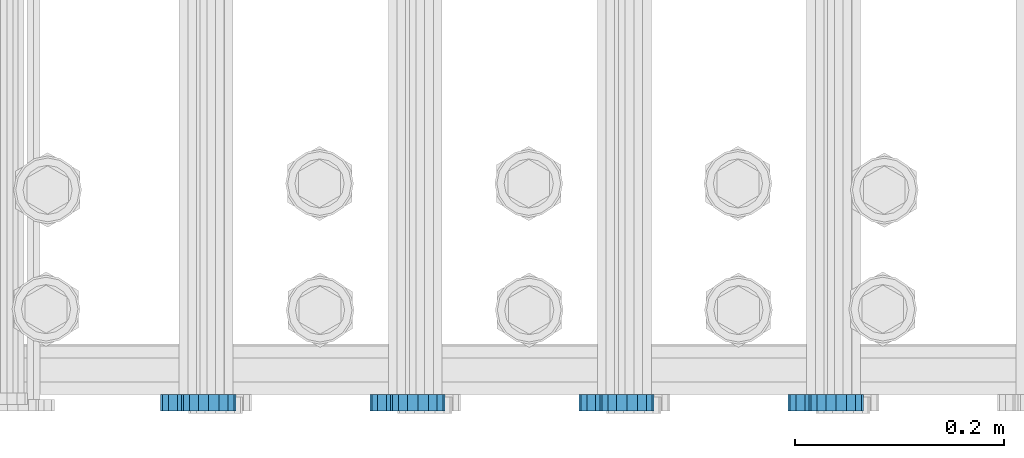
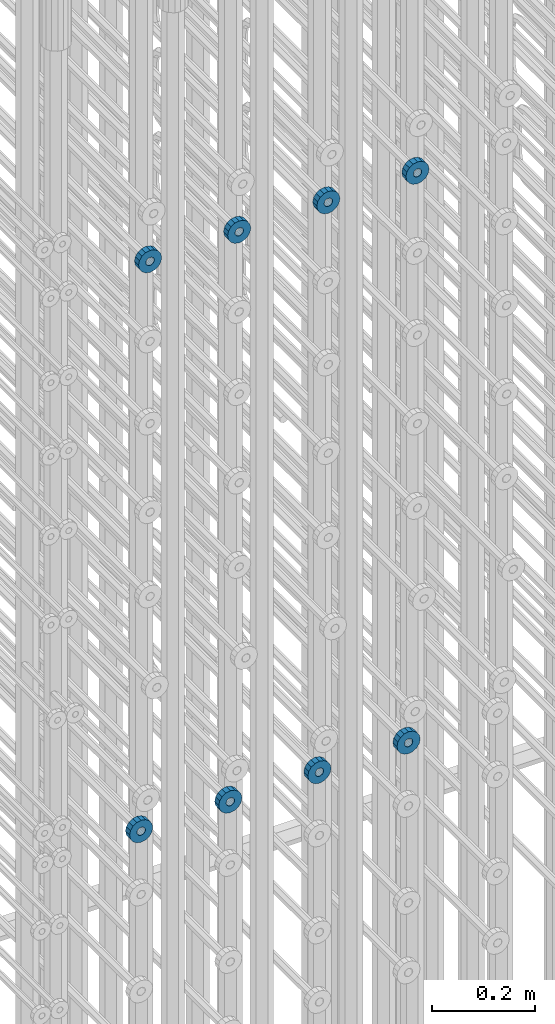
# One storey, part 130 of 177: 8 beams.
"""IFC2X3 building model written with IfcOpenShell, lengths in millimetres."""

from ifc_helpers import new_model, si_unit, frame, origin_with_axes, place, context, subcontext, project, spatial, faceted_brep, material, type_object, element, save


model = new_model("IFC2X3")

# Units and contexts
model_context_1 = context("Model", 3, precision=1e-05, world=origin_with_axes())
model_context_2 = context("Model", 3, precision=1e-05, world=origin_with_axes())
body_context = subcontext(model_context_2, "Body", "Model", "MODEL_VIEW")
ifc_project = project(units=[si_unit("LENGTHUNIT", "METRE", prefix="MILLI"), si_unit("AREAUNIT", "SQUARE_METRE"), si_unit("VOLUMEUNIT", "CUBIC_METRE"), si_unit("MASSUNIT", "GRAM", prefix="KILO"), si_unit("TIMEUNIT", "SECOND"), si_unit("PLANEANGLEUNIT", "RADIAN"), si_unit("SOLIDANGLEUNIT", "STERADIAN"), si_unit("THERMODYNAMICTEMPERATUREUNIT", "DEGREE_CELSIUS"), si_unit("LUMINOUSINTENSITYUNIT", "LUMEN")], contexts=[model_context_1])

# Site, building, storey
site_placement = place(None, origin_with_axes())
site = spatial("IfcSite", under=ifc_project, at=site_placement, CompositionType="ELEMENT")
building_placement = place(site_placement, origin_with_axes())
building = spatial("IfcBuilding", under=site, at=building_placement, Name="Undefined", CompositionType="ELEMENT")
storey_placement = place(building_placement, origin_with_axes())
storey = spatial("IfcBuildingStorey", under=building, at=storey_placement, Name="Undefined", CompositionType="ELEMENT", Elevation=0.0)

# Beams
ifc_material = material(Name="STEEL/Steel_Undefined")
beam_type = type_object("IfcBeamType", PredefinedType="NOTDEFINED")
beam_1_placement = place(storey_placement, frame((2032309.49847349, 6205075.98588033, 20799.9868114421), z_axis=(0.0, 0.0, -1.0), x_axis=(0.0, -1.0, 0.0)))
element("IfcBeam", 1, at=beam_1_placement, inside=storey, type_object=beam_type, material=ifc_material, context=body_context, shape_type="Brep", body=[
    faceted_brep([(0.0, -9.5, 0.0), (0.0, -8.77685555908829, 3.63549260746731), (16.0, -8.77685555908829, 3.63549260746731), (16.0, -9.5, 0.0), (0.0, -6.71751442085952, 6.71751442127061), (16.0, -6.71751442085952, 6.71751442127061), (0.0, -3.63549260701984, 8.77685555885546), (16.0, -3.63549260701984, 8.77685555885546), (-2.02452244836415e-12, 0.0, 9.5), (16.0, 0.0, 9.5), (0.0, 3.63549260701984, 8.77685555885546), (16.0, 3.63549260701984, 8.77685555885546), (0.0, 6.71751442085952, 6.71751442127061), (16.0, 6.71751442085952, 6.71751442127061), (0.0, 8.77685555908829, 3.63549260746731), (16.0, 8.77685555908829, 3.63549260746731), (0.0, 9.5, 0.0), (16.0, 9.5, 0.0), (0.0, 8.77685555908829, -3.63549260746731), (16.0, 8.77685555908829, -3.63549260746731), (0.0, 6.71751442085952, -6.71751442127061), (16.0, 6.71751442085952, -6.71751442127061), (0.0, 3.63549260701984, -8.77685555885546), (16.0, 3.63549260701984, -8.77685555885546), (2.02452244836415e-12, -3.69149155687865e-15, -9.5), (16.0, 0.0, -9.5), (0.0, -3.63549260701984, -8.77685555885546), (16.0, -3.63549260701984, -8.77685555885546), (0.0, -6.71751442085952, -6.71751442127061), (16.0, -6.71751442085952, -6.71751442127061), (0.0, -8.77685555908829, -3.63549260746731), (16.0, -8.77685555908829, -3.63549260746731), (0.0, -26.0, 0.0), (0.0, -24.0208678450435, -9.94976924149159), (16.0, -24.0208678450435, -9.94976924149159), (16.0, -26.0, 0.0), (0.0, -18.3847763109952, -18.3847763108497), (16.0, -18.3847763109952, -18.3847763108497), (0.0, -9.94976924173534, -24.0208678452946), (16.0, -9.94976924173534, -24.0208678452946), (0.0, 0.0, -26.0), (16.0, 0.0, -26.0), (0.0, 9.94976924173534, -24.0208678452946), (16.0, 9.94976924173534, -24.0208678452946), (0.0, 18.3847763109952, -18.3847763108497), (16.0, 18.3847763109952, -18.3847763108497), (0.0, 24.0208678450435, -9.94976924149159), (16.0, 24.0208678450435, -9.94976924149159), (0.0, 26.0, 0.0), (16.0, 26.0, 0.0), (0.0, 24.0208678450435, 9.94976924149159), (16.0, 24.0208678450435, 9.94976924149159), (0.0, 18.3847763109952, 18.3847763108497), (16.0, 18.3847763109952, 18.3847763108497), (0.0, 9.94976924173534, 24.0208678452946), (16.0, 9.94976924173534, 24.0208678452946), (0.0, 0.0, 26.0), (16.0, 0.0, 26.0), (0.0, -9.94976924173534, 24.0208678452946), (16.0, -9.94976924173534, 24.0208678452946), (0.0, -18.3847763109952, 18.3847763108497), (16.0, -18.3847763109952, 18.3847763108497), (0.0, -24.0208678450435, 9.94976924149159), (16.0, -24.0208678450435, 9.94976924149159)], [[[0, 1, 2, 3]], [[1, 4, 5, 2]], [[4, 6, 7, 5]], [[6, 8, 9, 7]], [[8, 10, 11, 9]], [[10, 12, 13, 11]], [[12, 14, 15, 13]], [[14, 16, 17, 15]], [[16, 18, 19, 17]], [[18, 20, 21, 19]], [[20, 22, 23, 21]], [[22, 24, 25, 23]], [[24, 26, 27, 25]], [[26, 28, 29, 27]], [[28, 30, 31, 29]], [[30, 0, 3, 31]], [[32, 33, 34, 35]], [[33, 36, 37, 34]], [[36, 38, 39, 37]], [[38, 40, 41, 39]], [[40, 42, 43, 41]], [[42, 44, 45, 43]], [[44, 46, 47, 45]], [[46, 48, 49, 47]], [[48, 50, 51, 49]], [[50, 52, 53, 51]], [[52, 54, 55, 53]], [[54, 56, 57, 55]], [[56, 58, 59, 57]], [[58, 60, 61, 59]], [[60, 62, 63, 61]], [[62, 32, 35, 63]], [[37, 39, 41, 43, 45, 47, 49, 51, 53, 55, 57, 59, 61, 63, 35, 34], [5, 7, 9, 11, 13, 15, 17, 19, 21, 23, 25, 27, 29, 31, 3, 2]], [[62, 60, 58, 56, 54, 52, 50, 48, 46, 44, 42, 40, 38, 36, 33, 32], [30, 28, 26, 24, 22, 20, 18, 16, 14, 12, 10, 8, 6, 4, 1, 0]]]),
])
beam_2_placement = place(storey_placement, frame((2032509.49847349, 6205075.98588033, 20799.9868114421), z_axis=(0.0, 0.0, -1.0), x_axis=(0.0, -1.0, 0.0)))
element("IfcBeam", 2, at=beam_2_placement, inside=storey, type_object=beam_type, material=ifc_material, context=body_context, shape_type="Brep", body=[
    faceted_brep([(0.0, -9.5, 0.0), (0.0, -8.77685555908829, 3.63549260746731), (16.0, -8.77685555908829, 3.63549260746731), (16.0, -9.5, 0.0), (0.0, -6.71751442085952, 6.71751442127061), (16.0, -6.71751442085952, 6.71751442127061), (0.0, -3.63549260701984, 8.77685555885546), (16.0, -3.63549260701984, 8.77685555885546), (-2.02452244836415e-12, 0.0, 9.5), (16.0, 0.0, 9.5), (0.0, 3.63549260701984, 8.77685555885546), (16.0, 3.63549260701984, 8.77685555885546), (0.0, 6.71751442085952, 6.71751442127061), (16.0, 6.71751442085952, 6.71751442127061), (0.0, 8.77685555908829, 3.63549260746731), (16.0, 8.77685555908829, 3.63549260746731), (0.0, 9.5, 0.0), (16.0, 9.5, 0.0), (0.0, 8.77685555908829, -3.63549260746731), (16.0, 8.77685555908829, -3.63549260746731), (0.0, 6.71751442085952, -6.71751442127061), (16.0, 6.71751442085952, -6.71751442127061), (0.0, 3.63549260701984, -8.77685555885546), (16.0, 3.63549260701984, -8.77685555885546), (2.02452244836415e-12, -3.69149155687865e-15, -9.5), (16.0, 0.0, -9.5), (0.0, -3.63549260701984, -8.77685555885546), (16.0, -3.63549260701984, -8.77685555885546), (0.0, -6.71751442085952, -6.71751442127061), (16.0, -6.71751442085952, -6.71751442127061), (0.0, -8.77685555908829, -3.63549260746731), (16.0, -8.77685555908829, -3.63549260746731), (0.0, -26.0, 0.0), (0.0, -24.0208678450435, -9.94976924149159), (16.0, -24.0208678450435, -9.94976924149159), (16.0, -26.0, 0.0), (0.0, -18.3847763109952, -18.3847763108497), (16.0, -18.3847763109952, -18.3847763108497), (0.0, -9.94976924173534, -24.0208678452946), (16.0, -9.94976924173534, -24.0208678452946), (0.0, 0.0, -26.0), (16.0, 0.0, -26.0), (0.0, 9.94976924173534, -24.0208678452946), (16.0, 9.94976924173534, -24.0208678452946), (0.0, 18.3847763109952, -18.3847763108497), (16.0, 18.3847763109952, -18.3847763108497), (0.0, 24.0208678450435, -9.94976924149159), (16.0, 24.0208678450435, -9.94976924149159), (0.0, 26.0, 0.0), (16.0, 26.0, 0.0), (0.0, 24.0208678450435, 9.94976924149159), (16.0, 24.0208678450435, 9.94976924149159), (0.0, 18.3847763109952, 18.3847763108497), (16.0, 18.3847763109952, 18.3847763108497), (0.0, 9.94976924173534, 24.0208678452946), (16.0, 9.94976924173534, 24.0208678452946), (0.0, 0.0, 26.0), (16.0, 0.0, 26.0), (0.0, -9.94976924173534, 24.0208678452946), (16.0, -9.94976924173534, 24.0208678452946), (0.0, -18.3847763109952, 18.3847763108497), (16.0, -18.3847763109952, 18.3847763108497), (0.0, -24.0208678450435, 9.94976924149159), (16.0, -24.0208678450435, 9.94976924149159)], [[[0, 1, 2, 3]], [[1, 4, 5, 2]], [[4, 6, 7, 5]], [[6, 8, 9, 7]], [[8, 10, 11, 9]], [[10, 12, 13, 11]], [[12, 14, 15, 13]], [[14, 16, 17, 15]], [[16, 18, 19, 17]], [[18, 20, 21, 19]], [[20, 22, 23, 21]], [[22, 24, 25, 23]], [[24, 26, 27, 25]], [[26, 28, 29, 27]], [[28, 30, 31, 29]], [[30, 0, 3, 31]], [[32, 33, 34, 35]], [[33, 36, 37, 34]], [[36, 38, 39, 37]], [[38, 40, 41, 39]], [[40, 42, 43, 41]], [[42, 44, 45, 43]], [[44, 46, 47, 45]], [[46, 48, 49, 47]], [[48, 50, 51, 49]], [[50, 52, 53, 51]], [[52, 54, 55, 53]], [[54, 56, 57, 55]], [[56, 58, 59, 57]], [[58, 60, 61, 59]], [[60, 62, 63, 61]], [[62, 32, 35, 63]], [[37, 39, 41, 43, 45, 47, 49, 51, 53, 55, 57, 59, 61, 63, 35, 34], [5, 7, 9, 11, 13, 15, 17, 19, 21, 23, 25, 27, 29, 31, 3, 2]], [[62, 60, 58, 56, 54, 52, 50, 48, 46, 44, 42, 40, 38, 36, 33, 32], [30, 28, 26, 24, 22, 20, 18, 16, 14, 12, 10, 8, 6, 4, 1, 0]]]),
])
beam_3_placement = place(storey_placement, frame((2032109.49847349, 6205075.98588033, 20799.9868114421), z_axis=(0.0, 0.0, -1.0), x_axis=(0.0, -1.0, 0.0)))
element("IfcBeam", 3, at=beam_3_placement, inside=storey, type_object=beam_type, material=ifc_material, context=body_context, shape_type="Brep", body=[
    faceted_brep([(0.0, -9.5, 0.0), (0.0, -8.77685555908829, 3.63549260746731), (16.0, -8.77685555908829, 3.63549260746731), (16.0, -9.5, 0.0), (0.0, -6.71751442085952, 6.71751442127061), (16.0, -6.71751442085952, 6.71751442127061), (0.0, -3.63549260701984, 8.77685555885546), (16.0, -3.63549260701984, 8.77685555885546), (-2.02452244836415e-12, 0.0, 9.5), (16.0, 0.0, 9.5), (0.0, 3.63549260701984, 8.77685555885546), (16.0, 3.63549260701984, 8.77685555885546), (0.0, 6.71751442085952, 6.71751442127061), (16.0, 6.71751442085952, 6.71751442127061), (0.0, 8.77685555908829, 3.63549260746731), (16.0, 8.77685555908829, 3.63549260746731), (0.0, 9.5, 0.0), (16.0, 9.5, 0.0), (0.0, 8.77685555908829, -3.63549260746731), (16.0, 8.77685555908829, -3.63549260746731), (0.0, 6.71751442085952, -6.71751442127061), (16.0, 6.71751442085952, -6.71751442127061), (0.0, 3.63549260701984, -8.77685555885546), (16.0, 3.63549260701984, -8.77685555885546), (2.02452244836415e-12, -3.69149155687865e-15, -9.5), (16.0, 0.0, -9.5), (0.0, -3.63549260701984, -8.77685555885546), (16.0, -3.63549260701984, -8.77685555885546), (0.0, -6.71751442085952, -6.71751442127061), (16.0, -6.71751442085952, -6.71751442127061), (0.0, -8.77685555908829, -3.63549260746731), (16.0, -8.77685555908829, -3.63549260746731), (0.0, -26.0, 0.0), (0.0, -24.0208678450435, -9.94976924149159), (16.0, -24.0208678450435, -9.94976924149159), (16.0, -26.0, 0.0), (0.0, -18.3847763109952, -18.3847763108497), (16.0, -18.3847763109952, -18.3847763108497), (0.0, -9.94976924173534, -24.0208678452946), (16.0, -9.94976924173534, -24.0208678452946), (0.0, 0.0, -26.0), (16.0, 0.0, -26.0), (0.0, 9.94976924173534, -24.0208678452946), (16.0, 9.94976924173534, -24.0208678452946), (0.0, 18.3847763109952, -18.3847763108497), (16.0, 18.3847763109952, -18.3847763108497), (0.0, 24.0208678450435, -9.94976924149159), (16.0, 24.0208678450435, -9.94976924149159), (0.0, 26.0, 0.0), (16.0, 26.0, 0.0), (0.0, 24.0208678450435, 9.94976924149159), (16.0, 24.0208678450435, 9.94976924149159), (0.0, 18.3847763109952, 18.3847763108497), (16.0, 18.3847763109952, 18.3847763108497), (0.0, 9.94976924173534, 24.0208678452946), (16.0, 9.94976924173534, 24.0208678452946), (0.0, 0.0, 26.0), (16.0, 0.0, 26.0), (0.0, -9.94976924173534, 24.0208678452946), (16.0, -9.94976924173534, 24.0208678452946), (0.0, -18.3847763109952, 18.3847763108497), (16.0, -18.3847763109952, 18.3847763108497), (0.0, -24.0208678450435, 9.94976924149159), (16.0, -24.0208678450435, 9.94976924149159)], [[[0, 1, 2, 3]], [[1, 4, 5, 2]], [[4, 6, 7, 5]], [[6, 8, 9, 7]], [[8, 10, 11, 9]], [[10, 12, 13, 11]], [[12, 14, 15, 13]], [[14, 16, 17, 15]], [[16, 18, 19, 17]], [[18, 20, 21, 19]], [[20, 22, 23, 21]], [[22, 24, 25, 23]], [[24, 26, 27, 25]], [[26, 28, 29, 27]], [[28, 30, 31, 29]], [[30, 0, 3, 31]], [[32, 33, 34, 35]], [[33, 36, 37, 34]], [[36, 38, 39, 37]], [[38, 40, 41, 39]], [[40, 42, 43, 41]], [[42, 44, 45, 43]], [[44, 46, 47, 45]], [[46, 48, 49, 47]], [[48, 50, 51, 49]], [[50, 52, 53, 51]], [[52, 54, 55, 53]], [[54, 56, 57, 55]], [[56, 58, 59, 57]], [[58, 60, 61, 59]], [[60, 62, 63, 61]], [[62, 32, 35, 63]], [[37, 39, 41, 43, 45, 47, 49, 51, 53, 55, 57, 59, 61, 63, 35, 34], [5, 7, 9, 11, 13, 15, 17, 19, 21, 23, 25, 27, 29, 31, 3, 2]], [[62, 60, 58, 56, 54, 52, 50, 48, 46, 44, 42, 40, 38, 36, 33, 32], [30, 28, 26, 24, 22, 20, 18, 16, 14, 12, 10, 8, 6, 4, 1, 0]]]),
])
beam_4_placement = place(storey_placement, frame((2032709.49847349, 6205075.98588033, 20799.9868114424), z_axis=(0.0, 0.0, -1.0), x_axis=(0.0, -1.0, 0.0)))
element("IfcBeam", 4, at=beam_4_placement, inside=storey, type_object=beam_type, material=ifc_material, context=body_context, shape_type="Brep", body=[
    faceted_brep([(0.0, -9.5, 0.0), (0.0, -8.77685555908829, 3.63549260746731), (16.0, -8.77685555908829, 3.63549260746731), (16.0, -9.5, 0.0), (0.0, -6.71751442085952, 6.71751442127061), (16.0, -6.71751442085952, 6.71751442127061), (0.0, -3.63549260701984, 8.77685555885546), (16.0, -3.63549260701984, 8.77685555885546), (-2.02452244836415e-12, 0.0, 9.5), (16.0, 0.0, 9.5), (0.0, 3.63549260701984, 8.77685555885546), (16.0, 3.63549260701984, 8.77685555885546), (0.0, 6.71751442085952, 6.71751442127061), (16.0, 6.71751442085952, 6.71751442127061), (0.0, 8.77685555908829, 3.63549260746731), (16.0, 8.77685555908829, 3.63549260746731), (0.0, 9.5, 0.0), (16.0, 9.5, 0.0), (0.0, 8.77685555908829, -3.63549260746731), (16.0, 8.77685555908829, -3.63549260746731), (0.0, 6.71751442085952, -6.71751442127061), (16.0, 6.71751442085952, -6.71751442127061), (0.0, 3.63549260701984, -8.77685555885546), (16.0, 3.63549260701984, -8.77685555885546), (2.02452244836415e-12, -3.69149155687865e-15, -9.5), (16.0, 0.0, -9.5), (0.0, -3.63549260701984, -8.77685555885546), (16.0, -3.63549260701984, -8.77685555885546), (0.0, -6.71751442085952, -6.71751442127061), (16.0, -6.71751442085952, -6.71751442127061), (0.0, -8.77685555908829, -3.63549260746731), (16.0, -8.77685555908829, -3.63549260746731), (0.0, -26.0, 0.0), (0.0, -24.0208678450435, -9.94976924149159), (16.0, -24.0208678450435, -9.94976924149159), (16.0, -26.0, 0.0), (0.0, -18.3847763109952, -18.3847763108497), (16.0, -18.3847763109952, -18.3847763108497), (0.0, -9.94976924173534, -24.0208678452946), (16.0, -9.94976924173534, -24.0208678452946), (0.0, 0.0, -26.0), (16.0, 0.0, -26.0), (0.0, 9.94976924173534, -24.0208678452946), (16.0, 9.94976924173534, -24.0208678452946), (0.0, 18.3847763109952, -18.3847763108497), (16.0, 18.3847763109952, -18.3847763108497), (0.0, 24.0208678450435, -9.94976924149159), (16.0, 24.0208678450435, -9.94976924149159), (0.0, 26.0, 0.0), (16.0, 26.0, 0.0), (0.0, 24.0208678450435, 9.94976924149159), (16.0, 24.0208678450435, 9.94976924149159), (0.0, 18.3847763109952, 18.3847763108497), (16.0, 18.3847763109952, 18.3847763108497), (0.0, 9.94976924173534, 24.0208678452946), (16.0, 9.94976924173534, 24.0208678452946), (0.0, 0.0, 26.0), (16.0, 0.0, 26.0), (0.0, -9.94976924173534, 24.0208678452946), (16.0, -9.94976924173534, 24.0208678452946), (0.0, -18.3847763109952, 18.3847763108497), (16.0, -18.3847763109952, 18.3847763108497), (0.0, -24.0208678450435, 9.94976924149159), (16.0, -24.0208678450435, 9.94976924149159)], [[[0, 1, 2, 3]], [[1, 4, 5, 2]], [[4, 6, 7, 5]], [[6, 8, 9, 7]], [[8, 10, 11, 9]], [[10, 12, 13, 11]], [[12, 14, 15, 13]], [[14, 16, 17, 15]], [[16, 18, 19, 17]], [[18, 20, 21, 19]], [[20, 22, 23, 21]], [[22, 24, 25, 23]], [[24, 26, 27, 25]], [[26, 28, 29, 27]], [[28, 30, 31, 29]], [[30, 0, 3, 31]], [[32, 33, 34, 35]], [[33, 36, 37, 34]], [[36, 38, 39, 37]], [[38, 40, 41, 39]], [[40, 42, 43, 41]], [[42, 44, 45, 43]], [[44, 46, 47, 45]], [[46, 48, 49, 47]], [[48, 50, 51, 49]], [[50, 52, 53, 51]], [[52, 54, 55, 53]], [[54, 56, 57, 55]], [[56, 58, 59, 57]], [[58, 60, 61, 59]], [[60, 62, 63, 61]], [[62, 32, 35, 63]], [[37, 39, 41, 43, 45, 47, 49, 51, 53, 55, 57, 59, 61, 63, 35, 34], [5, 7, 9, 11, 13, 15, 17, 19, 21, 23, 25, 27, 29, 31, 3, 2]], [[62, 60, 58, 56, 54, 52, 50, 48, 46, 44, 42, 40, 38, 36, 33, 32], [30, 28, 26, 24, 22, 20, 18, 16, 14, 12, 10, 8, 6, 4, 1, 0]]]),
])
beam_5_placement = place(storey_placement, frame((2032729.49847313, 6205075.98588636, 22144.986812672), z_axis=(0.0, 0.0, -1.0), x_axis=(0.0, -1.0, 0.0)))
element("IfcBeam", 5, at=beam_5_placement, inside=storey, type_object=beam_type, material=ifc_material, context=body_context, shape_type="Brep", body=[
    faceted_brep([(0.0, -9.5, 0.0), (0.0, -8.77685555908829, 3.63549260746731), (16.0, -8.77685555908829, 3.63549260746731), (16.0, -9.5, 0.0), (0.0, -6.71751442085952, 6.71751442127061), (16.0, -6.71751442085952, 6.71751442127061), (0.0, -3.63549260701984, 8.77685555885546), (16.0, -3.63549260701984, 8.77685555885546), (-2.02452244836415e-12, 0.0, 9.5), (16.0, 0.0, 9.5), (0.0, 3.63549260701984, 8.77685555885546), (16.0, 3.63549260701984, 8.77685555885546), (0.0, 6.71751442085952, 6.71751442127061), (16.0, 6.71751442085952, 6.71751442127061), (0.0, 8.77685555908829, 3.63549260746731), (16.0, 8.77685555908829, 3.63549260746731), (0.0, 9.5, 0.0), (16.0, 9.5, 0.0), (0.0, 8.77685555908829, -3.63549260746731), (16.0, 8.77685555908829, -3.63549260746731), (0.0, 6.71751442085952, -6.71751442127061), (16.0, 6.71751442085952, -6.71751442127061), (0.0, 3.63549260701984, -8.77685555885546), (16.0, 3.63549260701984, -8.77685555885546), (2.02452244836415e-12, -3.69149155687865e-15, -9.5), (16.0, 0.0, -9.5), (0.0, -3.63549260701984, -8.77685555885546), (16.0, -3.63549260701984, -8.77685555885546), (0.0, -6.71751442085952, -6.71751442127061), (16.0, -6.71751442085952, -6.71751442127061), (0.0, -8.77685555908829, -3.63549260746731), (16.0, -8.77685555908829, -3.63549260746731), (0.0, -26.0, 0.0), (0.0, -24.0208678450435, -9.94976924149159), (16.0, -24.0208678450435, -9.94976924149159), (16.0, -26.0, 0.0), (0.0, -18.3847763109952, -18.3847763108497), (16.0, -18.3847763109952, -18.3847763108497), (0.0, -9.94976924173534, -24.0208678452946), (16.0, -9.94976924173534, -24.0208678452946), (0.0, 0.0, -26.0), (16.0, 0.0, -26.0), (0.0, 9.94976924173534, -24.0208678452946), (16.0, 9.94976924173534, -24.0208678452946), (0.0, 18.3847763109952, -18.3847763108497), (16.0, 18.3847763109952, -18.3847763108497), (0.0, 24.0208678450435, -9.94976924149159), (16.0, 24.0208678450435, -9.94976924149159), (0.0, 26.0, 0.0), (16.0, 26.0, 0.0), (0.0, 24.0208678450435, 9.94976924149159), (16.0, 24.0208678450435, 9.94976924149159), (0.0, 18.3847763109952, 18.3847763108497), (16.0, 18.3847763109952, 18.3847763108497), (0.0, 9.94976924173534, 24.0208678452946), (16.0, 9.94976924173534, 24.0208678452946), (0.0, 0.0, 26.0), (16.0, 0.0, 26.0), (0.0, -9.94976924173534, 24.0208678452946), (16.0, -9.94976924173534, 24.0208678452946), (0.0, -18.3847763109952, 18.3847763108497), (16.0, -18.3847763109952, 18.3847763108497), (0.0, -24.0208678450435, 9.94976924149159), (16.0, -24.0208678450435, 9.94976924149159)], [[[0, 1, 2, 3]], [[1, 4, 5, 2]], [[4, 6, 7, 5]], [[6, 8, 9, 7]], [[8, 10, 11, 9]], [[10, 12, 13, 11]], [[12, 14, 15, 13]], [[14, 16, 17, 15]], [[16, 18, 19, 17]], [[18, 20, 21, 19]], [[20, 22, 23, 21]], [[22, 24, 25, 23]], [[24, 26, 27, 25]], [[26, 28, 29, 27]], [[28, 30, 31, 29]], [[30, 0, 3, 31]], [[32, 33, 34, 35]], [[33, 36, 37, 34]], [[36, 38, 39, 37]], [[38, 40, 41, 39]], [[40, 42, 43, 41]], [[42, 44, 45, 43]], [[44, 46, 47, 45]], [[46, 48, 49, 47]], [[48, 50, 51, 49]], [[50, 52, 53, 51]], [[52, 54, 55, 53]], [[54, 56, 57, 55]], [[56, 58, 59, 57]], [[58, 60, 61, 59]], [[60, 62, 63, 61]], [[62, 32, 35, 63]], [[37, 39, 41, 43, 45, 47, 49, 51, 53, 55, 57, 59, 61, 63, 35, 34], [5, 7, 9, 11, 13, 15, 17, 19, 21, 23, 25, 27, 29, 31, 3, 2]], [[62, 60, 58, 56, 54, 52, 50, 48, 46, 44, 42, 40, 38, 36, 33, 32], [30, 28, 26, 24, 22, 20, 18, 16, 14, 12, 10, 8, 6, 4, 1, 0]]]),
])
beam_6_placement = place(storey_placement, frame((2032529.49847313, 6205075.98588636, 22144.986812672), z_axis=(0.0, 0.0, -1.0), x_axis=(0.0, -1.0, 0.0)))
element("IfcBeam", 6, at=beam_6_placement, inside=storey, type_object=beam_type, material=ifc_material, context=body_context, shape_type="Brep", body=[
    faceted_brep([(0.0, -9.5, 0.0), (0.0, -8.77685555908829, 3.63549260746731), (16.0, -8.77685555908829, 3.63549260746731), (16.0, -9.5, 0.0), (0.0, -6.71751442085952, 6.71751442127061), (16.0, -6.71751442085952, 6.71751442127061), (0.0, -3.63549260701984, 8.77685555885546), (16.0, -3.63549260701984, 8.77685555885546), (-2.02452244836415e-12, 0.0, 9.5), (16.0, 0.0, 9.5), (0.0, 3.63549260701984, 8.77685555885546), (16.0, 3.63549260701984, 8.77685555885546), (0.0, 6.71751442085952, 6.71751442127061), (16.0, 6.71751442085952, 6.71751442127061), (0.0, 8.77685555908829, 3.63549260746731), (16.0, 8.77685555908829, 3.63549260746731), (0.0, 9.5, 0.0), (16.0, 9.5, 0.0), (0.0, 8.77685555908829, -3.63549260746731), (16.0, 8.77685555908829, -3.63549260746731), (0.0, 6.71751442085952, -6.71751442127061), (16.0, 6.71751442085952, -6.71751442127061), (0.0, 3.63549260701984, -8.77685555885546), (16.0, 3.63549260701984, -8.77685555885546), (2.02452244836415e-12, -3.69149155687865e-15, -9.5), (16.0, 0.0, -9.5), (0.0, -3.63549260701984, -8.77685555885546), (16.0, -3.63549260701984, -8.77685555885546), (0.0, -6.71751442085952, -6.71751442127061), (16.0, -6.71751442085952, -6.71751442127061), (0.0, -8.77685555908829, -3.63549260746731), (16.0, -8.77685555908829, -3.63549260746731), (0.0, -26.0, 0.0), (0.0, -24.0208678450435, -9.94976924149159), (16.0, -24.0208678450435, -9.94976924149159), (16.0, -26.0, 0.0), (0.0, -18.3847763109952, -18.3847763108497), (16.0, -18.3847763109952, -18.3847763108497), (0.0, -9.94976924173534, -24.0208678452946), (16.0, -9.94976924173534, -24.0208678452946), (0.0, 0.0, -26.0), (16.0, 0.0, -26.0), (0.0, 9.94976924173534, -24.0208678452946), (16.0, 9.94976924173534, -24.0208678452946), (0.0, 18.3847763109952, -18.3847763108497), (16.0, 18.3847763109952, -18.3847763108497), (0.0, 24.0208678450435, -9.94976924149159), (16.0, 24.0208678450435, -9.94976924149159), (0.0, 26.0, 0.0), (16.0, 26.0, 0.0), (0.0, 24.0208678450435, 9.94976924149159), (16.0, 24.0208678450435, 9.94976924149159), (0.0, 18.3847763109952, 18.3847763108497), (16.0, 18.3847763109952, 18.3847763108497), (0.0, 9.94976924173534, 24.0208678452946), (16.0, 9.94976924173534, 24.0208678452946), (0.0, 0.0, 26.0), (16.0, 0.0, 26.0), (0.0, -9.94976924173534, 24.0208678452946), (16.0, -9.94976924173534, 24.0208678452946), (0.0, -18.3847763109952, 18.3847763108497), (16.0, -18.3847763109952, 18.3847763108497), (0.0, -24.0208678450435, 9.94976924149159), (16.0, -24.0208678450435, 9.94976924149159)], [[[0, 1, 2, 3]], [[1, 4, 5, 2]], [[4, 6, 7, 5]], [[6, 8, 9, 7]], [[8, 10, 11, 9]], [[10, 12, 13, 11]], [[12, 14, 15, 13]], [[14, 16, 17, 15]], [[16, 18, 19, 17]], [[18, 20, 21, 19]], [[20, 22, 23, 21]], [[22, 24, 25, 23]], [[24, 26, 27, 25]], [[26, 28, 29, 27]], [[28, 30, 31, 29]], [[30, 0, 3, 31]], [[32, 33, 34, 35]], [[33, 36, 37, 34]], [[36, 38, 39, 37]], [[38, 40, 41, 39]], [[40, 42, 43, 41]], [[42, 44, 45, 43]], [[44, 46, 47, 45]], [[46, 48, 49, 47]], [[48, 50, 51, 49]], [[50, 52, 53, 51]], [[52, 54, 55, 53]], [[54, 56, 57, 55]], [[56, 58, 59, 57]], [[58, 60, 61, 59]], [[60, 62, 63, 61]], [[62, 32, 35, 63]], [[37, 39, 41, 43, 45, 47, 49, 51, 53, 55, 57, 59, 61, 63, 35, 34], [5, 7, 9, 11, 13, 15, 17, 19, 21, 23, 25, 27, 29, 31, 3, 2]], [[62, 60, 58, 56, 54, 52, 50, 48, 46, 44, 42, 40, 38, 36, 33, 32], [30, 28, 26, 24, 22, 20, 18, 16, 14, 12, 10, 8, 6, 4, 1, 0]]]),
])
beam_7_placement = place(storey_placement, frame((2032329.49847313, 6205075.98588636, 22144.986812672), z_axis=(0.0, 0.0, -1.0), x_axis=(0.0, -1.0, 0.0)))
element("IfcBeam", 7, at=beam_7_placement, inside=storey, type_object=beam_type, material=ifc_material, context=body_context, shape_type="Brep", body=[
    faceted_brep([(0.0, -9.5, 0.0), (0.0, -8.77685555908829, 3.63549260746731), (16.0, -8.77685555908829, 3.63549260746731), (16.0, -9.5, 0.0), (0.0, -6.71751442085952, 6.71751442127061), (16.0, -6.71751442085952, 6.71751442127061), (0.0, -3.63549260701984, 8.77685555885546), (16.0, -3.63549260701984, 8.77685555885546), (-2.02452244836415e-12, 0.0, 9.5), (16.0, 0.0, 9.5), (0.0, 3.63549260701984, 8.77685555885546), (16.0, 3.63549260701984, 8.77685555885546), (0.0, 6.71751442085952, 6.71751442127061), (16.0, 6.71751442085952, 6.71751442127061), (0.0, 8.77685555908829, 3.63549260746731), (16.0, 8.77685555908829, 3.63549260746731), (0.0, 9.5, 0.0), (16.0, 9.5, 0.0), (0.0, 8.77685555908829, -3.63549260746731), (16.0, 8.77685555908829, -3.63549260746731), (0.0, 6.71751442085952, -6.71751442127061), (16.0, 6.71751442085952, -6.71751442127061), (0.0, 3.63549260701984, -8.77685555885546), (16.0, 3.63549260701984, -8.77685555885546), (2.02452244836415e-12, -3.69149155687865e-15, -9.5), (16.0, 0.0, -9.5), (0.0, -3.63549260701984, -8.77685555885546), (16.0, -3.63549260701984, -8.77685555885546), (0.0, -6.71751442085952, -6.71751442127061), (16.0, -6.71751442085952, -6.71751442127061), (0.0, -8.77685555908829, -3.63549260746731), (16.0, -8.77685555908829, -3.63549260746731), (0.0, -26.0, 0.0), (0.0, -24.0208678450435, -9.94976924149159), (16.0, -24.0208678450435, -9.94976924149159), (16.0, -26.0, 0.0), (0.0, -18.3847763109952, -18.3847763108497), (16.0, -18.3847763109952, -18.3847763108497), (0.0, -9.94976924173534, -24.0208678452946), (16.0, -9.94976924173534, -24.0208678452946), (0.0, 0.0, -26.0), (16.0, 0.0, -26.0), (0.0, 9.94976924173534, -24.0208678452946), (16.0, 9.94976924173534, -24.0208678452946), (0.0, 18.3847763109952, -18.3847763108497), (16.0, 18.3847763109952, -18.3847763108497), (0.0, 24.0208678450435, -9.94976924149159), (16.0, 24.0208678450435, -9.94976924149159), (0.0, 26.0, 0.0), (16.0, 26.0, 0.0), (0.0, 24.0208678450435, 9.94976924149159), (16.0, 24.0208678450435, 9.94976924149159), (0.0, 18.3847763109952, 18.3847763108497), (16.0, 18.3847763109952, 18.3847763108497), (0.0, 9.94976924173534, 24.0208678452946), (16.0, 9.94976924173534, 24.0208678452946), (0.0, 0.0, 26.0), (16.0, 0.0, 26.0), (0.0, -9.94976924173534, 24.0208678452946), (16.0, -9.94976924173534, 24.0208678452946), (0.0, -18.3847763109952, 18.3847763108497), (16.0, -18.3847763109952, 18.3847763108497), (0.0, -24.0208678450435, 9.94976924149159), (16.0, -24.0208678450435, 9.94976924149159)], [[[0, 1, 2, 3]], [[1, 4, 5, 2]], [[4, 6, 7, 5]], [[6, 8, 9, 7]], [[8, 10, 11, 9]], [[10, 12, 13, 11]], [[12, 14, 15, 13]], [[14, 16, 17, 15]], [[16, 18, 19, 17]], [[18, 20, 21, 19]], [[20, 22, 23, 21]], [[22, 24, 25, 23]], [[24, 26, 27, 25]], [[26, 28, 29, 27]], [[28, 30, 31, 29]], [[30, 0, 3, 31]], [[32, 33, 34, 35]], [[33, 36, 37, 34]], [[36, 38, 39, 37]], [[38, 40, 41, 39]], [[40, 42, 43, 41]], [[42, 44, 45, 43]], [[44, 46, 47, 45]], [[46, 48, 49, 47]], [[48, 50, 51, 49]], [[50, 52, 53, 51]], [[52, 54, 55, 53]], [[54, 56, 57, 55]], [[56, 58, 59, 57]], [[58, 60, 61, 59]], [[60, 62, 63, 61]], [[62, 32, 35, 63]], [[37, 39, 41, 43, 45, 47, 49, 51, 53, 55, 57, 59, 61, 63, 35, 34], [5, 7, 9, 11, 13, 15, 17, 19, 21, 23, 25, 27, 29, 31, 3, 2]], [[62, 60, 58, 56, 54, 52, 50, 48, 46, 44, 42, 40, 38, 36, 33, 32], [30, 28, 26, 24, 22, 20, 18, 16, 14, 12, 10, 8, 6, 4, 1, 0]]]),
])
beam_8_placement = place(storey_placement, frame((2032129.49847313, 6205075.98588636, 22144.986812672), z_axis=(0.0, 0.0, -1.0), x_axis=(0.0, -1.0, 0.0)))
element("IfcBeam", 8, at=beam_8_placement, inside=storey, type_object=beam_type, material=ifc_material, context=body_context, shape_type="Brep", body=[
    faceted_brep([(0.0, -9.5, 0.0), (0.0, -8.77685555908829, 3.63549260746731), (16.0, -8.77685555908829, 3.63549260746731), (16.0, -9.5, 0.0), (0.0, -6.71751442085952, 6.71751442127061), (16.0, -6.71751442085952, 6.71751442127061), (0.0, -3.63549260701984, 8.77685555885546), (16.0, -3.63549260701984, 8.77685555885546), (-2.02452244836415e-12, 0.0, 9.5), (16.0, 0.0, 9.5), (0.0, 3.63549260701984, 8.77685555885546), (16.0, 3.63549260701984, 8.77685555885546), (0.0, 6.71751442085952, 6.71751442127061), (16.0, 6.71751442085952, 6.71751442127061), (0.0, 8.77685555908829, 3.63549260746731), (16.0, 8.77685555908829, 3.63549260746731), (0.0, 9.5, 0.0), (16.0, 9.5, 0.0), (0.0, 8.77685555908829, -3.63549260746731), (16.0, 8.77685555908829, -3.63549260746731), (0.0, 6.71751442085952, -6.71751442127061), (16.0, 6.71751442085952, -6.71751442127061), (0.0, 3.63549260701984, -8.77685555885546), (16.0, 3.63549260701984, -8.77685555885546), (2.02452244836415e-12, -3.69149155687865e-15, -9.5), (16.0, 0.0, -9.5), (0.0, -3.63549260701984, -8.77685555885546), (16.0, -3.63549260701984, -8.77685555885546), (0.0, -6.71751442085952, -6.71751442127061), (16.0, -6.71751442085952, -6.71751442127061), (0.0, -8.77685555908829, -3.63549260746731), (16.0, -8.77685555908829, -3.63549260746731), (0.0, -26.0, 0.0), (0.0, -24.0208678450435, -9.94976924149159), (16.0, -24.0208678450435, -9.94976924149159), (16.0, -26.0, 0.0), (0.0, -18.3847763109952, -18.3847763108497), (16.0, -18.3847763109952, -18.3847763108497), (0.0, -9.94976924173534, -24.0208678452946), (16.0, -9.94976924173534, -24.0208678452946), (0.0, 0.0, -26.0), (16.0, 0.0, -26.0), (0.0, 9.94976924173534, -24.0208678452946), (16.0, 9.94976924173534, -24.0208678452946), (0.0, 18.3847763109952, -18.3847763108497), (16.0, 18.3847763109952, -18.3847763108497), (0.0, 24.0208678450435, -9.94976924149159), (16.0, 24.0208678450435, -9.94976924149159), (0.0, 26.0, 0.0), (16.0, 26.0, 0.0), (0.0, 24.0208678450435, 9.94976924149159), (16.0, 24.0208678450435, 9.94976924149159), (0.0, 18.3847763109952, 18.3847763108497), (16.0, 18.3847763109952, 18.3847763108497), (0.0, 9.94976924173534, 24.0208678452946), (16.0, 9.94976924173534, 24.0208678452946), (0.0, 0.0, 26.0), (16.0, 0.0, 26.0), (0.0, -9.94976924173534, 24.0208678452946), (16.0, -9.94976924173534, 24.0208678452946), (0.0, -18.3847763109952, 18.3847763108497), (16.0, -18.3847763109952, 18.3847763108497), (0.0, -24.0208678450435, 9.94976924149159), (16.0, -24.0208678450435, 9.94976924149159)], [[[0, 1, 2, 3]], [[1, 4, 5, 2]], [[4, 6, 7, 5]], [[6, 8, 9, 7]], [[8, 10, 11, 9]], [[10, 12, 13, 11]], [[12, 14, 15, 13]], [[14, 16, 17, 15]], [[16, 18, 19, 17]], [[18, 20, 21, 19]], [[20, 22, 23, 21]], [[22, 24, 25, 23]], [[24, 26, 27, 25]], [[26, 28, 29, 27]], [[28, 30, 31, 29]], [[30, 0, 3, 31]], [[32, 33, 34, 35]], [[33, 36, 37, 34]], [[36, 38, 39, 37]], [[38, 40, 41, 39]], [[40, 42, 43, 41]], [[42, 44, 45, 43]], [[44, 46, 47, 45]], [[46, 48, 49, 47]], [[48, 50, 51, 49]], [[50, 52, 53, 51]], [[52, 54, 55, 53]], [[54, 56, 57, 55]], [[56, 58, 59, 57]], [[58, 60, 61, 59]], [[60, 62, 63, 61]], [[62, 32, 35, 63]], [[37, 39, 41, 43, 45, 47, 49, 51, 53, 55, 57, 59, 61, 63, 35, 34], [5, 7, 9, 11, 13, 15, 17, 19, 21, 23, 25, 27, 29, 31, 3, 2]], [[62, 60, 58, 56, 54, 52, 50, 48, 46, 44, 42, 40, 38, 36, 33, 32], [30, 28, 26, 24, 22, 20, 18, 16, 14, 12, 10, 8, 6, 4, 1, 0]]]),
])

save(model, "model.ifc")
